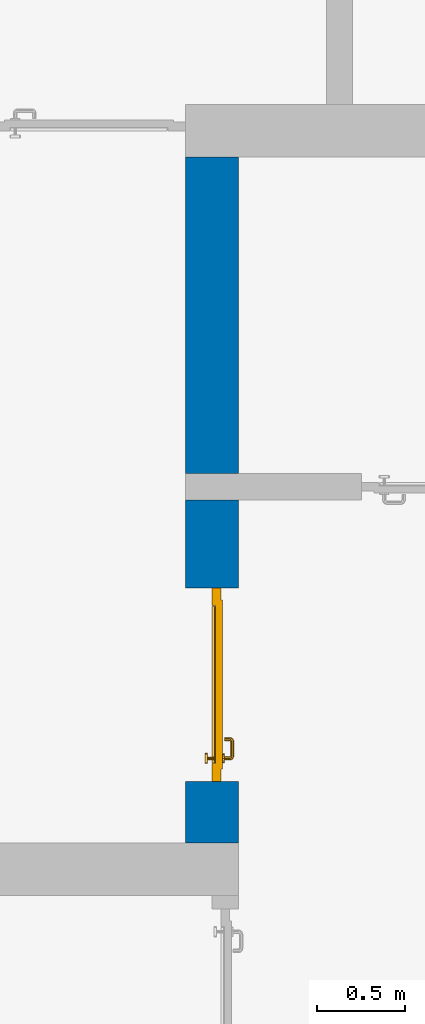
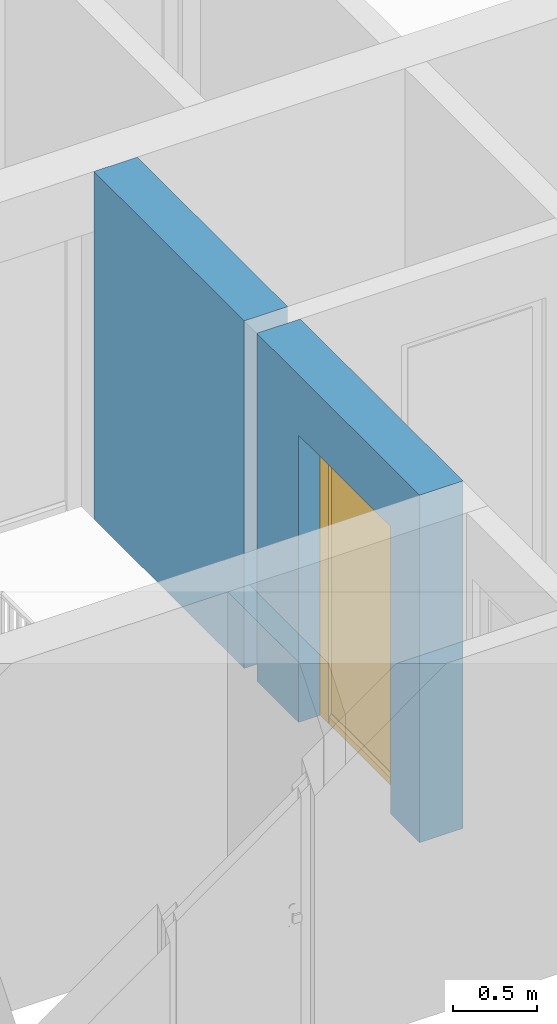
# One storey, part 15 of 54: 1 door, 1 wall, 1 opening.
"""IFC4 building model written with IfcOpenShell, lengths in metres."""

from ifc_helpers import new_model, entity, si_unit, converted_unit, derived_unit, direction, frame, origin_with_axes, place, context, subcontext, project, spatial, polygons, source, transform, mapped, material, type_object, element, fill, save


model = new_model("IFC4")

# Units and contexts
model_context = context("Model", 3, precision=1e-05, world=origin_with_axes(), true_north=direction((0.0, 1.0)))
body_context = subcontext(model_context, "Body", "Model", "MODEL_VIEW")
ifc_project = project(units=[si_unit("LENGTHUNIT", "METRE"), si_unit("AREAUNIT", "SQUARE_METRE"), si_unit("VOLUMEUNIT", "CUBIC_METRE"), converted_unit("PLANEANGLEUNIT", "DEGREE", entity("IfcPlaneAngleMeasure", 0.0174532925199), si_unit("PLANEANGLEUNIT", "RADIAN"), dimensions=[0, 0, 0, 0, 0, 0, 0]), converted_unit("TIMEUNIT", "Year", entity("IfcTimeMeasure", 31556926.0), si_unit("TIMEUNIT", "SECOND"), dimensions=[0, 0, 1, 0, 0, 0, 0]), si_unit("MASSUNIT", "GRAM", prefix="KILO"), si_unit("THERMODYNAMICTEMPERATUREUNIT", "DEGREE_CELSIUS"), si_unit("LUMINOUSINTENSITYUNIT", "LUMEN"), si_unit("ENERGYUNIT", "JOULE", prefix="MEGA"), derived_unit("THERMALCONDUCTANCEUNIT", [(si_unit("POWERUNIT", "WATT"), 1), (si_unit("LENGTHUNIT", "METRE"), -1), (si_unit("THERMODYNAMICTEMPERATUREUNIT", "KELVIN"), -1)]), derived_unit("SPECIFICHEATCAPACITYUNIT", [(si_unit("ENERGYUNIT", "JOULE"), 1), (si_unit("MASSUNIT", "GRAM", prefix="KILO"), -1), (si_unit("THERMODYNAMICTEMPERATUREUNIT", "KELVIN"), -1)]), derived_unit("MASSDENSITYUNIT", [(si_unit("MASSUNIT", "GRAM", prefix="KILO"), 1), (si_unit("VOLUMEUNIT", "CUBIC_METRE"), -1)])], contexts=[model_context])

# Site, building, storey
site_placement = place(None, origin_with_axes())
site = spatial("IfcSite", under=ifc_project, at=site_placement, CompositionType="ELEMENT")
building_placement = place(site_placement, origin_with_axes())
building = spatial("IfcBuilding", under=site, at=building_placement, CompositionType="ELEMENT")
storey_placement = place(building_placement, frame((0.0, 0.0, 9.18), z_axis=(0.0, 0.0, 1.0), x_axis=(1.0, 0.0, 0.0)))
storey = spatial("IfcBuildingStorey", under=building, at=storey_placement, Name="3. Geschoss", CompositionType="ELEMENT", Elevation=9.18)

# Wall, opening, door
ifc_material = material()
wall_type = type_object("IfcWallType", Name="300", PredefinedType="NOTDEFINED")
wall_placement = place(storey_placement, frame((2.8378006196, -2.52881223104, 0.0), z_axis=(0.0, 0.0, 1.0), x_axis=(0.0, 1.0, 0.0)))
wall = element("IfcWall", 1, at=wall_placement, inside=storey, type_object=wall_type, material=ifc_material, Name="Wand-001", PredefinedType="NOTDEFINED", context=body_context, shape_type="Tessellation", body=[
    polygons([(3.9, 0.3, 0.0), (3.9, 0.3, 2.54), (3.9, 0.0, 2.54), (3.9, 0.0, 0.0), (2.1, 0.3, 0.0), (2.1, 0.3, 2.54), (2.1, 0.0, 2.54), (2.1, 0.0, 0.0)], [[[1, 2, 3, 4]], [[5, 6, 2, 1]], [[6, 7, 3, 2]], [[4, 3, 7, 8]], [[5, 1, 4, 8]], [[8, 7, 6, 5]]], closed=True),
    polygons([(0.35, 0.0, 0.0), (0.35, 0.0, 2.1), (1.45, 0.0, 2.1), (1.45, 0.0, 0.0), (1.95, 0.0, 0.0), (1.95, 0.0, 2.54), (0.0, 0.0, 2.54), (0.0, 0.0, 0.0), (0.35, 0.15, 0.0), (0.35, 0.3, 0.0), (0.35, 0.3, 2.1), (1.45, 0.3, 2.1), (1.45, 0.15, 0.0), (1.45, 0.3, 0.0), (1.95, 0.3, 0.0), (1.95, 0.3, 2.54), (0.0, 0.3, 2.54), (0.0, 0.3, 0.0)], [[[1, 2, 3, 4, 5, 6, 7, 8]], [[2, 1, 9, 10, 11]], [[3, 2, 11, 12]], [[13, 4, 3, 12, 14]], [[4, 13, 14, 15, 5]], [[6, 5, 15, 16]], [[6, 16, 17, 7]], [[17, 18, 8, 7]], [[9, 1, 8, 18, 10]], [[15, 14, 12, 11, 10, 18, 17, 16]]], closed=True),
])
opening_placement = place(wall_placement, frame((0.9, 0.0, 0.0), z_axis=(0.0, 0.0, 1.0), x_axis=(1.0, 0.0, 0.0)))
opening = element("IfcOpeningElement", 2, at=opening_placement, cuts=wall, context=body_context, identifier="Reference", shape_type="Tessellation", body=[
    polygons([(-0.55, 0.15, 0.0), (-0.55, 0.15, 2.1), (-0.55, 0.301, 2.1), (-0.55, 0.301, 0.0), (-0.55, -0.001, 0.0), (-0.55, -0.001, 2.1), (0.55, 0.15, 2.1), (0.55, 0.301, 2.1), (0.55, -0.001, 2.1), (0.55, 0.301, 0.0), (0.55, 0.15, 0.0), (0.55, -0.001, 0.0)], [[[1, 2, 3, 4]], [[2, 1, 5, 6]], [[7, 8, 3, 2, 6, 9]], [[8, 10, 4, 3]], [[1, 4, 10, 11, 12, 5]], [[6, 5, 12, 9]], [[7, 11, 10, 8]], [[11, 7, 9, 12]]], closed=True),
])
door_type = type_object("IfcDoorType", Name="Eingang 01 1-Fl 26", OperationType="SINGLE_SWING_LEFT", PredefinedType="DOOR")
shared_shape = source(origin_with_axes(), body_context, "Body", "Tessellation", [
    polygons([(-0.55, -0.05, 0.0), (-0.55, -0.05, 2.1), (-0.55, -0.03, 2.1), (-0.55, -0.03, 0.0), (-0.45, -0.05, 0.0), (-0.45, -0.05, 2.0), (-0.1301, -0.05, 2.0), (-0.0001, -0.05, 2.0), (0.45, -0.05, 2.0), (0.45, -0.05, 0.0), (0.55, -0.05, 0.0), (0.55, -0.05, 2.1), (0.55, -0.03, 2.1), (0.55, -0.03, 0.0), (0.45, -0.03, 0.0), (0.45, -0.03, 2.0), (-0.0001, -0.03, 2.0), (-0.1301, -0.03, 2.0), (-0.45, -0.03, 2.0), (-0.45, -0.03, 0.0)], [[[1, 2, 3, 4]], [[1, 5, 6, 7, 8, 9, 10, 11, 12, 2]], [[2, 12, 13, 3]], [[4, 3, 13, 14, 15, 16, 17, 18, 19, 20]], [[5, 1, 4, 20]], [[6, 5, 20, 19]], [[7, 6, 19, 18]], [[8, 7, 18, 17]], [[9, 8, 17, 16]], [[10, 9, 16, 15]], [[11, 10, 15, 14]], [[12, 11, 14, 13]]], closed=True),
    polygons([(-0.55, -0.03, 0.0), (-0.55, -0.03, 2.1), (-0.55, 0.0, 2.1), (-0.55, 0.0, 0.0), (-0.48, -0.03, 0.0), (-0.48, -0.03, 2.03), (-0.1001, -0.03, 2.03), (-0.0301, -0.03, 2.03), (0.48, -0.03, 2.03), (0.48, -0.03, 0.0), (0.55, -0.03, 0.0), (0.55, -0.03, 2.1), (0.55, 0.0, 2.1), (0.55, 0.0, 0.0), (0.48, 0.0, 0.0), (0.48, 0.0, 2.03), (-0.0301, 0.0, 2.03), (-0.1001, 0.0, 2.03), (-0.48, 0.0, 2.03), (-0.48, 0.0, 0.0)], [[[1, 2, 3, 4]], [[1, 5, 6, 7, 8, 9, 10, 11, 12, 2]], [[2, 12, 13, 3]], [[4, 3, 13, 14, 15, 16, 17, 18, 19, 20]], [[5, 1, 4, 20]], [[6, 5, 20, 19]], [[7, 6, 19, 18]], [[8, 7, 18, 17]], [[9, 8, 17, 16]], [[10, 9, 16, 15]], [[11, 10, 15, 14]], [[12, 11, 14, 13]]], closed=True),
    polygons([(-0.48, 0.01, 0.0), (-0.48, 0.01, 2.03), (0.48, 0.01, 2.03), (0.48, 0.01, 0.0), (-0.48, -0.03, 0.0), (-0.48, -0.03, 2.03), (0.48, -0.03, 2.03), (0.48, -0.03, 0.0)], [[[1, 2, 3, 4]], [[1, 5, 6, 2]], [[2, 6, 7, 3]], [[3, 7, 8, 4]], [[4, 8, 5, 1]], [[8, 7, 6, 5]]], closed=True),
    polygons([(-0.445, -0.05, 0.0), (0.445, -0.05, 0.0), (0.445, -0.05, 0.05), (-0.445, -0.05, 0.05), (-0.445, -0.03, 0.0), (0.445, -0.03, 0.0), (0.445, -0.03, 0.07), (0.445, -0.035, 0.07), (-0.445, -0.035, 0.07), (-0.445, -0.03, 0.07)], [[[1, 2, 3, 4]], [[5, 6, 2, 1]], [[2, 6, 7, 8, 3]], [[4, 3, 8, 9]], [[1, 4, 9, 10, 5]], [[10, 7, 6, 5]], [[9, 8, 7, 10]]], closed=True),
    polygons([(0.4335, 0.02, 1.0733826859), (0.42, 0.02, 1.077), (0.42, 0.0199, 1.077), (0.4335, 0.0199, 1.0733826859), (0.443382685902, 0.02, 1.0635), (0.447, 0.02, 1.05), (0.443382685902, 0.02, 1.0365), (0.4335, 0.02, 1.0266173141), (0.42, 0.02, 1.023), (0.4065, 0.02, 1.0266173141), (0.396617314098, 0.02, 1.0365), (0.393, 0.02, 1.05), (0.396617314098, 0.02, 1.0635), (0.4065, 0.02, 1.0733826859), (0.4065, 0.0199, 1.0733826859), (0.42, 0.0101, 1.077), (0.4335, 0.0101, 1.0733826859), (0.443382685902, 0.0199, 1.0635), (0.447, 0.0199, 1.05), (0.443382685902, 0.0199, 1.0365), (0.4335, 0.0199, 1.0266173141), (0.42, 0.0199, 1.023), (0.4065, 0.0199, 1.0266173141), (0.396617314098, 0.0199, 1.0365), (0.393, 0.0199, 1.05), (0.396617314098, 0.0199, 1.0635), (0.4065, 0.0101, 1.0733826859), (0.42, 0.01, 1.077), (0.4335, 0.01, 1.0733826859), (0.443382685902, 0.0101, 1.0635), (0.447, 0.0101, 1.05), (0.443382685902, 0.0101, 1.0365), (0.4335, 0.0101, 1.0266173141), (0.42, 0.0101, 1.023), (0.4065, 0.0101, 1.0266173141), (0.396617314098, 0.0101, 1.0365), (0.393, 0.0101, 1.05), (0.396617314098, 0.0101, 1.0635), (0.4065, 0.01, 1.0733826859), (0.396617314098, 0.01, 1.0635), (0.393, 0.01, 1.05), (0.396617314098, 0.01, 1.0365), (0.4065, 0.01, 1.0266173141), (0.42, 0.01, 1.023), (0.4335, 0.01, 1.0266173141), (0.443382685902, 0.01, 1.0365), (0.447, 0.01, 1.05), (0.443382685902, 0.01, 1.0635)], [[[1, 2, 3, 4]], [[2, 1, 5, 6, 7, 8, 9, 10, 11, 12, 13, 14]], [[2, 14, 15, 3]], [[4, 3, 16, 17]], [[5, 1, 4, 18]], [[6, 5, 18, 19]], [[7, 6, 19, 20]], [[8, 7, 20, 21]], [[9, 8, 21, 22]], [[10, 9, 22, 23]], [[11, 10, 23, 24]], [[12, 11, 24, 25]], [[13, 12, 25, 26]], [[14, 13, 26, 15]], [[3, 15, 27, 16]], [[17, 16, 28, 29]], [[18, 4, 17, 30]], [[19, 18, 30, 31]], [[20, 19, 31, 32]], [[21, 20, 32, 33]], [[22, 21, 33, 34]], [[23, 22, 34, 35]], [[24, 23, 35, 36]], [[25, 24, 36, 37]], [[26, 25, 37, 38]], [[15, 26, 38, 27]], [[16, 27, 39, 28]], [[28, 39, 40, 41, 42, 43, 44, 45, 46, 47, 48, 29]], [[30, 17, 29, 48]], [[31, 30, 48, 47]], [[32, 31, 47, 46]], [[33, 32, 46, 45]], [[34, 33, 45, 44]], [[35, 34, 44, 43]], [[36, 35, 43, 42]], [[37, 36, 42, 41]], [[38, 37, 41, 40]], [[27, 38, 40, 39]]], closed=True),
    polygons([(0.412532169224, 0.019, 0.959692280177), (0.413279754556, 0.019, 0.961639806549), (0.40705, 0.019, 0.972430057958), (0.397569942042, 0.019, 0.96295), (0.415, 0.019, 0.952886751346), (0.415, 0.019, 0.9544), (0.412532169224, 0.02, 0.959692280177), (0.413279754556, 0.02, 0.961639806549), (0.414624817685, 0.02, 0.965143815798), (0.414624817685, 0.019, 0.965143815798), (0.42, 0.019, 0.967425445323), (0.42, 0.019, 0.9759), (0.407, 0.019, 0.972516660498), (0.397483339502, 0.019, 0.963), (0.415, 0.019, 0.95), (0.3941, 0.019, 0.95), (0.415, 0.019, 0.947113248654), (0.415, 0.019, 0.941339745962), (0.415, 0.019, 0.9375), (0.415, 0.02, 0.9375), (0.415, 0.02, 0.941339745962), (0.415, 0.02, 0.947113248654), (0.415, 0.02, 0.95), (0.415, 0.02, 0.952886751346), (0.415, 0.02, 0.9544), (0.396703916638, 0.02, 0.96345), (0.40655, 0.02, 0.973296083362), (0.42, 0.02, 0.9769), (0.42, 0.02, 0.967425445323), (0.425375182315, 0.019, 0.965143815798), (0.426720245444, 0.019, 0.961639806549), (0.43295, 0.019, 0.972430057958), (0.42, 0.019, 0.976), (0.407, 0.0189, 0.972516660498), (0.397483339502, 0.0189, 0.963), (0.394, 0.019, 0.95), (0.397569942042, 0.019, 0.93705), (0.40705, 0.019, 0.927569942042), (0.42, 0.019, 0.9241), (0.42, 0.019, 0.9325), (0.416464466094, 0.019, 0.933964466094), (0.416464466094, 0.02, 0.933964466094), (0.42, 0.02, 0.9231), (0.40655, 0.02, 0.926703916638), (0.42, 0.02, 0.9325), (0.396703916638, 0.02, 0.93655), (0.3931, 0.02, 0.95), (0.396617314098, 0.02, 0.9635), (0.4065, 0.02, 0.973382685902), (0.42, 0.02, 0.977), (0.425375182315, 0.02, 0.965143815798), (0.43345, 0.02, 0.973296083362), (0.426720245444, 0.02, 0.961639806549), (0.427467830776, 0.02, 0.959692280177), (0.427467830776, 0.019, 0.959692280177), (0.425, 0.019, 0.9544), (0.425, 0.019, 0.952886751346), (0.442430057958, 0.019, 0.96295), (0.433, 0.019, 0.972516660498), (0.42, 0.0189, 0.976), (0.407, 0.0101, 0.972516660498), (0.397483339502, 0.0101, 0.963), (0.394, 0.0189, 0.95), (0.397483339502, 0.019, 0.937), (0.407, 0.019, 0.927483339502), (0.42, 0.019, 0.924), (0.43295, 0.019, 0.927569942042), (0.425, 0.019, 0.941339745962), (0.425, 0.019, 0.9375), (0.423535533906, 0.019, 0.933964466094), (0.42, 0.02, 0.923), (0.4065, 0.02, 0.926617314098), (0.43345, 0.02, 0.926703916638), (0.423535533906, 0.02, 0.933964466094), (0.425, 0.02, 0.9375), (0.425, 0.02, 0.941339745962), (0.396617314098, 0.02, 0.9365), (0.393, 0.02, 0.95), (0.396617314098, 0.0199, 0.9635), (0.4065, 0.0199, 0.973382685902), (0.42, 0.0199, 0.977), (0.4335, 0.02, 0.973382685902), (0.443296083362, 0.02, 0.96345), (0.425, 0.02, 0.952886751346), (0.425, 0.02, 0.9544), (0.425, 0.02, 0.95), (0.425, 0.02, 0.947113248654), (0.425, 0.019, 0.947113248654), (0.425, 0.019, 0.95), (0.4459, 0.019, 0.95), (0.442516660498, 0.019, 0.963), (0.433, 0.0189, 0.972516660498), (0.42, 0.0101, 0.976), (0.407, 0.01, 0.972516660498), (0.397483339502, 0.01, 0.963), (0.394, 0.0101, 0.95), (0.397483339502, 0.0189, 0.937), (0.407, 0.0189, 0.927483339502), (0.42, 0.0189, 0.924), (0.433, 0.019, 0.927483339502), (0.442430057958, 0.019, 0.93705), (0.42, 0.0199, 0.923), (0.4065, 0.0199, 0.926617314098), (0.4335, 0.02, 0.926617314098), (0.443296083362, 0.02, 0.93655), (0.396617314098, 0.0199, 0.9365), (0.393, 0.0199, 0.95), (0.396617314098, 0.0101, 0.9635), (0.4065, 0.0101, 0.973382685902), (0.42, 0.0101, 0.977), (0.4335, 0.0199, 0.973382685902), (0.443382685902, 0.02, 0.9635), (0.4469, 0.02, 0.95), (0.446, 0.019, 0.95), (0.442516660498, 0.0189, 0.963), (0.433, 0.0101, 0.972516660498), (0.42, 0.01, 0.976), (0.40695, 0.01, 0.972603263039), (0.397396736961, 0.01, 0.96305), (0.394, 0.01, 0.95), (0.397483339502, 0.0101, 0.937), (0.407, 0.0101, 0.927483339502), (0.42, 0.0101, 0.924), (0.433, 0.0189, 0.927483339502), (0.442516660498, 0.019, 0.937), (0.42, 0.0101, 0.923), (0.4065, 0.0101, 0.926617314098), (0.4335, 0.0199, 0.926617314098), (0.443382685902, 0.02, 0.9365), (0.396617314098, 0.0101, 0.9365), (0.393, 0.0101, 0.95), (0.396617314098, 0.01, 0.9635), (0.4065, 0.01, 0.973382685902), (0.42, 0.01, 0.977), (0.4335, 0.0101, 0.973382685902), (0.443382685902, 0.0199, 0.9635), (0.447, 0.02, 0.95), (0.446, 0.0189, 0.95), (0.442516660498, 0.0101, 0.963), (0.433, 0.01, 0.972516660498), (0.42, 0.01, 0.9761), (0.40655, 0.01, 0.973296083362), (0.396703916638, 0.01, 0.96345), (0.3939, 0.01, 0.95), (0.397483339502, 0.01, 0.937), (0.407, 0.01, 0.927483339502), (0.42, 0.01, 0.924), (0.433, 0.0101, 0.927483339502), (0.442516660498, 0.0189, 0.937), (0.42, 0.01, 0.923), (0.4065, 0.01, 0.926617314098), (0.4335, 0.0101, 0.926617314098), (0.443382685902, 0.0199, 0.9365), (0.396617314098, 0.01, 0.9365), (0.393, 0.01, 0.95), (0.42, 0.01, 0.9769), (0.4335, 0.01, 0.973382685902), (0.443382685902, 0.0101, 0.9635), (0.447, 0.0199, 0.95), (0.446, 0.0101, 0.95), (0.442516660498, 0.01, 0.963), (0.43305, 0.01, 0.972603263039), (0.3931, 0.01, 0.95), (0.397396736961, 0.01, 0.93695), (0.40695, 0.01, 0.927396736961), (0.42, 0.01, 0.9239), (0.433, 0.01, 0.927483339502), (0.442516660498, 0.0101, 0.937), (0.42, 0.01, 0.9231), (0.40655, 0.01, 0.926703916638), (0.4335, 0.01, 0.926617314098), (0.443382685902, 0.0101, 0.9365), (0.396703916638, 0.01, 0.93655), (0.43345, 0.01, 0.973296083362), (0.443382685902, 0.01, 0.9635), (0.447, 0.0101, 0.95), (0.446, 0.01, 0.95), (0.442603263039, 0.01, 0.96305), (0.43305, 0.01, 0.927396736961), (0.442516660498, 0.01, 0.937), (0.43345, 0.01, 0.926703916638), (0.443382685902, 0.01, 0.9365), (0.443296083362, 0.01, 0.96345), (0.447, 0.01, 0.95), (0.4461, 0.01, 0.95), (0.442603263039, 0.01, 0.93695), (0.443296083362, 0.01, 0.93655), (0.4469, 0.01, 0.95)], [[[1, 2, 3, 4, 5, 6]], [[1, 7, 8, 9, 10, 2]], [[10, 11, 12, 3, 2]], [[4, 3, 13, 14]], [[15, 5, 4, 16]], [[6, 5, 15, 17, 18, 19, 20, 21, 22, 23, 24, 25]], [[6, 25, 7, 1]], [[7, 25, 24, 26, 27, 8]], [[9, 8, 27, 28, 29]], [[10, 9, 29, 11]], [[30, 31, 32, 12, 11]], [[3, 12, 33, 13]], [[14, 13, 34, 35]], [[16, 4, 14, 36]], [[17, 15, 16, 37]], [[18, 17, 37, 38]], [[38, 39, 40, 41, 19, 18]], [[19, 41, 42, 20]], [[43, 44, 21, 20, 42, 45]], [[22, 21, 44, 46]], [[23, 22, 46, 47]], [[24, 23, 47, 26]], [[48, 49, 27, 26]], [[49, 50, 28, 27]], [[51, 29, 28, 52, 53]], [[11, 29, 51, 30]], [[30, 51, 53, 54, 55, 31]], [[55, 56, 57, 58, 32, 31]], [[12, 32, 59, 33]], [[13, 33, 60, 34]], [[35, 34, 61, 62]], [[36, 14, 35, 63]], [[37, 16, 36, 64]], [[38, 37, 64, 65]], [[39, 38, 65, 66]], [[39, 67, 68, 69, 70, 40]], [[41, 40, 45, 42]], [[71, 72, 44, 43]], [[73, 43, 45, 74, 75, 76]], [[72, 77, 46, 44]], [[77, 78, 47, 46]], [[78, 48, 26, 47]], [[79, 80, 49, 48]], [[80, 81, 50, 49]], [[50, 82, 52, 28]], [[54, 53, 52, 83, 84, 85]], [[55, 54, 85, 56]], [[85, 84, 86, 87, 76, 75, 69, 68, 88, 89, 57, 56]], [[57, 89, 90, 58]], [[32, 58, 91, 59]], [[33, 59, 92, 60]], [[34, 60, 93, 61]], [[62, 61, 94, 95]], [[63, 35, 62, 96]], [[64, 36, 63, 97]], [[65, 64, 97, 98]], [[66, 65, 98, 99]], [[67, 39, 66, 100]], [[88, 68, 67, 101]], [[70, 69, 75, 74]], [[40, 70, 74, 45]], [[102, 103, 72, 71]], [[104, 71, 43, 73]], [[76, 87, 105, 73]], [[103, 106, 77, 72]], [[106, 107, 78, 77]], [[107, 79, 48, 78]], [[108, 109, 80, 79]], [[109, 110, 81, 80]], [[81, 111, 82, 50]], [[82, 112, 83, 52]], [[86, 84, 83, 113]], [[87, 86, 113, 105]], [[89, 88, 101, 90]], [[58, 90, 114, 91]], [[59, 91, 115, 92]], [[60, 92, 116, 93]], [[61, 93, 117, 94]], [[95, 94, 118, 119]], [[96, 62, 95, 120]], [[97, 63, 96, 121]], [[98, 97, 121, 122]], [[99, 98, 122, 123]], [[100, 66, 99, 124]], [[101, 67, 100, 125]], [[126, 127, 103, 102]], [[128, 102, 71, 104]], [[129, 104, 73, 105]], [[127, 130, 106, 103]], [[130, 131, 107, 106]], [[131, 108, 79, 107]], [[132, 133, 109, 108]], [[133, 134, 110, 109]], [[110, 135, 111, 81]], [[111, 136, 112, 82]], [[112, 137, 113, 83]], [[137, 129, 105, 113]], [[90, 101, 125, 114]], [[91, 114, 138, 115]], [[92, 115, 139, 116]], [[93, 116, 140, 117]], [[94, 117, 141, 118]], [[119, 118, 142, 143]], [[120, 95, 119, 144]], [[121, 96, 120, 145]], [[122, 121, 145, 146]], [[123, 122, 146, 147]], [[124, 99, 123, 148]], [[125, 100, 124, 149]], [[150, 151, 127, 126]], [[152, 126, 102, 128]], [[153, 128, 104, 129]], [[151, 154, 130, 127]], [[154, 155, 131, 130]], [[155, 132, 108, 131]], [[143, 142, 133, 132]], [[142, 156, 134, 133]], [[134, 157, 135, 110]], [[135, 158, 136, 111]], [[136, 159, 137, 112]], [[159, 153, 129, 137]], [[114, 125, 149, 138]], [[115, 138, 160, 139]], [[116, 139, 161, 140]], [[117, 140, 162, 141]], [[118, 141, 156, 142]], [[144, 119, 143, 163]], [[145, 120, 144, 164]], [[146, 145, 164, 165]], [[147, 146, 165, 166]], [[148, 123, 147, 167]], [[149, 124, 148, 168]], [[169, 170, 151, 150]], [[171, 150, 126, 152]], [[172, 152, 128, 153]], [[170, 173, 154, 151]], [[173, 163, 155, 154]], [[163, 143, 132, 155]], [[156, 174, 157, 134]], [[157, 175, 158, 135]], [[158, 176, 159, 136]], [[176, 172, 153, 159]], [[138, 149, 168, 160]], [[139, 160, 177, 161]], [[140, 161, 178, 162]], [[141, 162, 174, 156]], [[164, 144, 163, 173]], [[165, 164, 173, 170]], [[166, 165, 170, 169]], [[167, 147, 166, 179]], [[168, 148, 167, 180]], [[181, 169, 150, 171]], [[182, 171, 152, 172]], [[174, 183, 175, 157]], [[175, 184, 176, 158]], [[184, 182, 172, 176]], [[160, 168, 180, 177]], [[161, 177, 185, 178]], [[162, 178, 183, 174]], [[179, 166, 169, 181]], [[180, 167, 179, 186]], [[187, 181, 171, 182]], [[183, 188, 184, 175]], [[188, 187, 182, 184]], [[177, 180, 186, 185]], [[178, 185, 188, 183]], [[186, 179, 181, 187]], [[185, 186, 187, 188]]], closed=True),
    polygons([(0.43, 0.02, 1.05), (0.427071067812, 0.02, 1.04292893219), (0.427071067812, 0.050696439392, 1.04292893219), (0.43, 0.0509849140336, 1.05), (0.42, 0.02, 1.04), (0.42, 0.05, 1.04), (0.425518993221, 0.0584992452783, 1.04292893219), (0.428277987014, 0.0596420579258, 1.05), (0.427071067812, 0.02, 1.05707106781), (0.427071067812, 0.050696439392, 1.05707106781), (0.412928932188, 0.02, 1.04292893219), (0.412928932188, 0.049303560608, 1.04292893219), (0.418858192988, 0.0557402514855, 1.04), (0.420704557509, 0.0657045575088, 1.04292893219), (0.422816199938, 0.0678161999379, 1.05), (0.425518993221, 0.0584992452783, 1.05707106781), (0.42, 0.02, 1.06), (0.42, 0.05, 1.06), (0.41, 0.02, 1.05), (0.41, 0.0490150859664, 1.05), (0.412197392755, 0.0529812576926, 1.04292893219), (0.415606601718, 0.0606066017178, 1.04), (0.413499245278, 0.0705189932208, 1.04292893219), (0.414642057926, 0.0732779870137, 1.05), (0.420704557509, 0.0657045575088, 1.05707106781), (0.418858192988, 0.0557402514855, 1.06), (0.412928932188, 0.02, 1.05707106781), (0.412928932188, 0.049303560608, 1.05707106781), (0.409438398962, 0.0518384450452, 1.05), (0.410508645927, 0.0555086459268, 1.04292893219), (0.410740251485, 0.0638581929877, 1.04), (0.405696439392, 0.0720710678119, 1.04292893219), (0.405984914034, 0.075, 1.05), (0.413499245278, 0.0705189932208, 1.05707106781), (0.415606601718, 0.0606066017178, 1.06), (0.412197392755, 0.0529812576926, 1.05707106781), (0.408397003498, 0.0533970034977, 1.05), (0.407981257693, 0.0571973927545, 1.04292893219), (0.405, 0.065, 1.04), (0.324303560608, 0.0720710678119, 1.04292893219), (0.324015085966, 0.075, 1.05), (0.405696439392, 0.0720710678119, 1.05707106781), (0.410740251485, 0.0638581929877, 1.06), (0.410508645927, 0.0555086459268, 1.05707106781), (0.406838445045, 0.0544383989617, 1.05), (0.404303560608, 0.0579289321881, 1.04292893219), (0.325, 0.065, 1.04), (0.316500754722, 0.0705189932208, 1.04292893219), (0.315357942074, 0.0732779870137, 1.05), (0.324303560608, 0.0720710678119, 1.05707106781), (0.405, 0.065, 1.06), (0.407981257693, 0.0571973927545, 1.05707106781), (0.404015085966, 0.055, 1.05), (0.325696439392, 0.0579289321881, 1.04292893219), (0.319259748515, 0.0638581929877, 1.04), (0.309295442491, 0.0657045575088, 1.04292893219), (0.307183800062, 0.0678161999379, 1.05), (0.316500754722, 0.0705189932208, 1.05707106781), (0.325, 0.065, 1.06), (0.404303560608, 0.0579289321881, 1.05707106781), (0.325984914034, 0.055, 1.05), (0.322018742307, 0.0571973927545, 1.04292893219), (0.314393398282, 0.0606066017178, 1.04), (0.304481006779, 0.0584992452783, 1.04292893219), (0.301722012986, 0.0596420579258, 1.05), (0.309295442491, 0.0657045575088, 1.05707106781), (0.319259748515, 0.0638581929877, 1.06), (0.325696439392, 0.0579289321881, 1.05707106781), (0.323161554955, 0.0544383989617, 1.05), (0.319491354073, 0.0555086459268, 1.04292893219), (0.311141807012, 0.0557402514855, 1.04), (0.302928932188, 0.050696439392, 1.04292893219), (0.3, 0.0509849140336, 1.05), (0.304481006779, 0.0584992452783, 1.05707106781), (0.314393398282, 0.0606066017178, 1.06), (0.322018742307, 0.0571973927545, 1.05707106781), (0.321602996502, 0.0533970034977, 1.05), (0.317802607245, 0.0529812576926, 1.04292893219), (0.31, 0.05, 1.04), (0.302928932188, 0.02, 1.04292893219), (0.3, 0.02, 1.05), (0.302928932188, 0.050696439392, 1.05707106781), (0.311141807012, 0.0557402514855, 1.06), (0.319491354073, 0.0555086459268, 1.05707106781), (0.320561601038, 0.0518384450452, 1.05), (0.317071067812, 0.049303560608, 1.04292893219), (0.31, 0.02, 1.04), (0.317071067812, 0.02, 1.04292893219), (0.32, 0.02, 1.05), (0.317071067812, 0.02, 1.05707106781), (0.31, 0.02, 1.06), (0.302928932188, 0.02, 1.05707106781), (0.31, 0.05, 1.06), (0.317802607245, 0.0529812576926, 1.05707106781), (0.32, 0.0490150859664, 1.05), (0.317071067812, 0.049303560608, 1.05707106781)], [[[1, 2, 3, 4]], [[2, 5, 6, 3]], [[4, 3, 7, 8]], [[9, 1, 4, 10]], [[5, 11, 12, 6]], [[3, 6, 13, 7]], [[8, 7, 14, 15]], [[10, 4, 8, 16]], [[17, 9, 10, 18]], [[11, 19, 20, 12]], [[6, 12, 21, 13]], [[7, 13, 22, 14]], [[15, 14, 23, 24]], [[16, 8, 15, 25]], [[18, 10, 16, 26]], [[27, 17, 18, 28]], [[19, 27, 28, 20]], [[12, 20, 29, 21]], [[13, 21, 30, 22]], [[14, 22, 31, 23]], [[24, 23, 32, 33]], [[25, 15, 24, 34]], [[26, 16, 25, 35]], [[28, 18, 26, 36]], [[20, 28, 36, 29]], [[21, 29, 37, 30]], [[22, 30, 38, 31]], [[23, 31, 39, 32]], [[33, 32, 40, 41]], [[34, 24, 33, 42]], [[35, 25, 34, 43]], [[36, 26, 35, 44]], [[29, 36, 44, 37]], [[30, 37, 45, 38]], [[31, 38, 46, 39]], [[32, 39, 47, 40]], [[41, 40, 48, 49]], [[42, 33, 41, 50]], [[43, 34, 42, 51]], [[44, 35, 43, 52]], [[37, 44, 52, 45]], [[38, 45, 53, 46]], [[39, 46, 54, 47]], [[40, 47, 55, 48]], [[49, 48, 56, 57]], [[50, 41, 49, 58]], [[51, 42, 50, 59]], [[52, 43, 51, 60]], [[45, 52, 60, 53]], [[46, 53, 61, 54]], [[47, 54, 62, 55]], [[48, 55, 63, 56]], [[57, 56, 64, 65]], [[58, 49, 57, 66]], [[59, 50, 58, 67]], [[60, 51, 59, 68]], [[53, 60, 68, 61]], [[54, 61, 69, 62]], [[55, 62, 70, 63]], [[56, 63, 71, 64]], [[65, 64, 72, 73]], [[66, 57, 65, 74]], [[67, 58, 66, 75]], [[68, 59, 67, 76]], [[61, 68, 76, 69]], [[62, 69, 77, 70]], [[63, 70, 78, 71]], [[64, 71, 79, 72]], [[73, 72, 80, 81]], [[74, 65, 73, 82]], [[75, 66, 74, 83]], [[76, 67, 75, 84]], [[69, 76, 84, 77]], [[70, 77, 85, 78]], [[71, 78, 86, 79]], [[72, 79, 87, 80]], [[81, 80, 87, 88, 89, 90, 91, 92]], [[82, 73, 81, 92]], [[83, 74, 82, 93]], [[84, 75, 83, 94]], [[77, 84, 94, 85]], [[78, 85, 95, 86]], [[79, 86, 88, 87]], [[86, 95, 89, 88]], [[95, 96, 90, 89]], [[96, 93, 91, 90]], [[93, 82, 92, 91]], [[94, 83, 93, 96]], [[85, 94, 96, 95]]], closed=False),
    polygons([(0.414696699141, -0.035, 1.04469669914), (0.4125, -0.035, 1.05), (0.414696699141, -0.035, 1.05530330086), (0.42, -0.035, 1.0575), (0.425303300859, -0.035, 1.05530330086), (0.4275, -0.035, 1.05), (0.425303300859, -0.035, 1.04469669914), (0.42, -0.035, 1.0425), (0.414696699141, -0.075, 1.04469669914), (0.4125, -0.075, 1.05), (0.414696699141, -0.075, 1.05530330086), (0.42, -0.075, 1.0575), (0.425303300859, -0.075, 1.05530330086), (0.4275, -0.075, 1.05), (0.425303300859, -0.075, 1.04469669914), (0.42, -0.075, 1.0425)], [[[1, 2, 3, 4, 5, 6, 7, 8]], [[1, 9, 10, 2]], [[2, 10, 11, 3]], [[3, 11, 12, 4]], [[4, 12, 13, 5]], [[5, 13, 14, 6]], [[6, 14, 15, 7]], [[7, 15, 16, 8]], [[8, 16, 9, 1]], [[9, 16, 15, 14, 13, 12, 11, 10]]], closed=True),
    polygons([(0.445, -0.03, 0.975), (0.445, -0.035, 0.975), (0.443096988313, -0.035, 0.965432914191), (0.443096988313, -0.03, 0.965432914191), (0.445, -0.03, 1.1), (0.445, -0.035, 1.1), (0.443096988313, -0.035, 1.10956708581), (0.43767766953, -0.035, 1.11767766953), (0.429567085809, -0.035, 1.12309698831), (0.42, -0.035, 1.125), (0.410432914191, -0.035, 1.12309698831), (0.40232233047, -0.035, 1.11767766953), (0.396903011687, -0.035, 1.10956708581), (0.395, -0.035, 1.1), (0.395, -0.035, 0.975), (0.396903011687, -0.035, 0.965432914191), (0.40232233047, -0.035, 0.95732233047), (0.410432914191, -0.035, 0.951903011687), (0.42, -0.035, 0.95), (0.429567085809, -0.035, 0.951903011687), (0.43767766953, -0.035, 0.95732233047), (0.43767766953, -0.03, 0.95732233047), (0.429567085809, -0.03, 0.951903011687), (0.42, -0.03, 0.95), (0.410432914191, -0.03, 0.951903011687), (0.40232233047, -0.03, 0.95732233047), (0.396903011687, -0.03, 0.965432914191), (0.395, -0.03, 0.975), (0.395, -0.03, 1.1), (0.396903011687, -0.03, 1.10956708581), (0.40232233047, -0.03, 1.11767766953), (0.410432914191, -0.03, 1.12309698831), (0.42, -0.03, 1.125), (0.429567085809, -0.03, 1.12309698831), (0.43767766953, -0.03, 1.11767766953), (0.443096988313, -0.03, 1.10956708581)], [[[1, 2, 3, 4]], [[5, 6, 2, 1]], [[2, 6, 7, 8, 9, 10, 11, 12, 13, 14, 15, 16, 17, 18, 19, 20, 21, 3]], [[4, 3, 21, 22]], [[1, 4, 22, 23, 24, 25, 26, 27, 28, 29, 30, 31, 32, 33, 34, 35, 36, 5]], [[36, 7, 6, 5]], [[35, 8, 7, 36]], [[34, 9, 8, 35]], [[33, 10, 9, 34]], [[32, 11, 10, 33]], [[31, 12, 11, 32]], [[30, 13, 12, 31]], [[29, 14, 13, 30]], [[28, 15, 14, 29]], [[27, 16, 15, 28]], [[26, 17, 16, 27]], [[25, 18, 17, 26]], [[24, 19, 18, 25]], [[23, 20, 19, 24]], [[22, 21, 20, 23]]], closed=True),
    polygons([(0.44, -0.075, 1.08), (0.44, -0.09, 1.08), (0.445, -0.09, 1.07866025404), (0.445, -0.075, 1.07866025404), (0.4, -0.075, 1.08), (0.4, -0.09, 1.08), (0.395, -0.09, 1.07866025404), (0.391339745962, -0.09, 1.075), (0.39, -0.09, 1.07), (0.39, -0.09, 1.03), (0.391339745962, -0.09, 1.025), (0.395, -0.09, 1.02133974596), (0.4, -0.09, 1.02), (0.44, -0.09, 1.02), (0.445, -0.09, 1.02133974596), (0.448660254038, -0.09, 1.025), (0.45, -0.09, 1.03), (0.45, -0.09, 1.07), (0.448660254038, -0.09, 1.075), (0.448660254038, -0.075, 1.075), (0.45, -0.075, 1.07), (0.45, -0.075, 1.03), (0.448660254038, -0.075, 1.025), (0.445, -0.075, 1.02133974596), (0.44, -0.075, 1.02), (0.4, -0.075, 1.02), (0.395, -0.075, 1.02133974596), (0.391339745962, -0.075, 1.025), (0.39, -0.075, 1.03), (0.39, -0.075, 1.07), (0.391339745962, -0.075, 1.075), (0.395, -0.075, 1.07866025404)], [[[1, 2, 3, 4]], [[5, 6, 2, 1]], [[2, 6, 7, 8, 9, 10, 11, 12, 13, 14, 15, 16, 17, 18, 19, 3]], [[4, 3, 19, 20]], [[1, 4, 20, 21, 22, 23, 24, 25, 26, 27, 28, 29, 30, 31, 32, 5]], [[32, 7, 6, 5]], [[31, 8, 7, 32]], [[30, 9, 8, 31]], [[29, 10, 9, 30]], [[28, 11, 10, 29]], [[27, 12, 11, 28]], [[26, 13, 12, 27]], [[25, 14, 13, 26]], [[24, 15, 14, 25]], [[23, 16, 15, 24]], [[22, 17, 16, 23]], [[21, 18, 17, 22]], [[20, 19, 18, 21]]], closed=True),
])
door_placement = place(opening_placement, frame((0.45, 0.0, 0.0), z_axis=(0.0, 0.0, 1.0), x_axis=(-1.0, 0.0, 0.0)))
door = element("IfcDoor", 3, at=door_placement, inside=storey, type_object=door_type, OverallHeight=2.1, OverallWidth=1.1, PredefinedType="DOOR", context=body_context, shape_type="MappedRepresentation", body=[
    mapped(shared_shape, transform((0.45, -0.1, 0.0))),
])
fill(opening, door)

save(model, "model.ifc")
